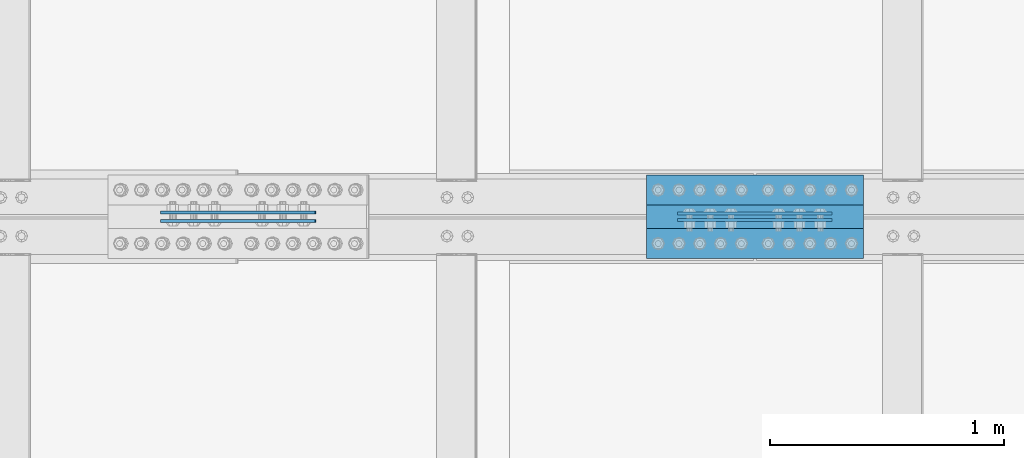
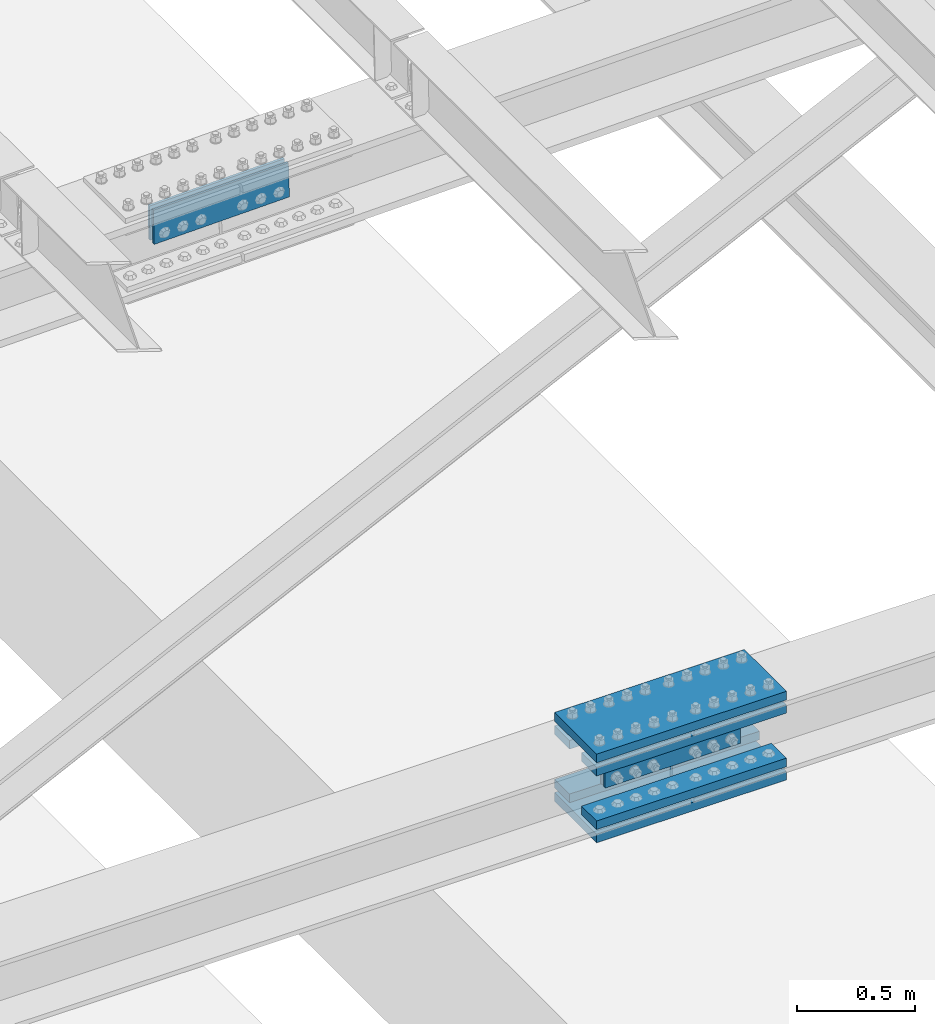
# One storey, part 2355 of 3843: 10 beams, 2 elements without a shape of their own.
"""IFC2X3 building model written with IfcOpenShell, lengths in millimetres."""

from ifc_helpers import new_model, si_unit, frame, origin_with_axes, place, context, subcontext, project, spatial, faceted_brep, material, type_object, element, aggregate, save


model = new_model("IFC2X3")

# Units and contexts
model_context = context("Model", 3, precision=1e-05, world=origin_with_axes())
body_context = subcontext(model_context, "Body", "Model", "MODEL_VIEW")
ifc_project = project(units=[si_unit("LENGTHUNIT", "METRE", prefix="MILLI"), si_unit("AREAUNIT", "SQUARE_METRE"), si_unit("VOLUMEUNIT", "CUBIC_METRE"), si_unit("MASSUNIT", "GRAM", prefix="KILO"), si_unit("TIMEUNIT", "SECOND"), si_unit("PLANEANGLEUNIT", "RADIAN"), si_unit("SOLIDANGLEUNIT", "STERADIAN"), si_unit("THERMODYNAMICTEMPERATUREUNIT", "DEGREE_CELSIUS"), si_unit("LUMINOUSINTENSITYUNIT", "LUMEN")], contexts=[model_context])

# Site, building, storey
site_placement = place(None, origin_with_axes())
site = spatial("IfcSite", under=ifc_project, at=site_placement, CompositionType="ELEMENT")
building_placement = place(site_placement, origin_with_axes())
building = spatial("IfcBuilding", under=site, at=building_placement, Name="Undefined", CompositionType="ELEMENT")
storey_placement = place(building_placement, origin_with_axes())
storey = spatial("IfcBuildingStorey", under=building, at=storey_placement, Name="Undefined", CompositionType="ELEMENT", Elevation=0.0)

# Assembly, beams
assembly_1_placement = place(storey_placement, origin_with_axes())
assembly_1 = element("IfcElementAssembly", 1, at=assembly_1_placement, inside=storey, Name="BEAM", AssemblyPlace="NOTDEFINED", PredefinedType="RIGID_FRAME")
ifc_material = material(Name="STEEL/A572-50")
beam_type_1 = type_object("IfcBeamType", PredefinedType="NOTDEFINED")
beam_1_placement = place(assembly_1_placement, frame((68046.60000049, 58901.80625, 42348.2024746643), z_axis=(-0.000295010000132606, 0.0, 0.999999956484549), x_axis=(-0.999999956484549, 0.0, -0.000295010000137217)))
beam_1 = element("IfcBeam", 2, at=beam_1_placement, type_object=beam_type_1, material=ifc_material, Name="PLATE", context=body_context, shape_type="Brep", body=[
    faceted_brep([(1.45519152283669e-11, 6.35000000000582, -88.8999999998996), (0.0, 6.34999999999854, 88.9000015258789), (660.399999982677, 6.35000000000582, 88.8999999999651), (660.399999982707, 6.35000000000582, -88.8999999998268), (0.0, -6.34999999999854, 88.9000015258789), (660.399999982677, -6.35000000000582, 88.8999999999651), (1.45519152283669e-11, -6.35000000000582, -88.8999999998996), (660.399999982707, -6.35000000000582, -88.8999999998268)], [[[0, 1, 2, 3]], [[1, 4, 5, 2]], [[4, 6, 7, 5]], [[6, 0, 3, 7]], [[5, 7, 3, 2]], [[6, 4, 1, 0]]]),
])
beam_2_placement = place(assembly_1_placement, frame((68046.60000049, 58928.79375, 42348.2024746643), z_axis=(-0.000295010000132606, 0.0, 0.999999956484549), x_axis=(-0.999999956484549, 0.0, -0.000295010000137217)))
beam_2 = element("IfcBeam", 3, at=beam_2_placement, type_object=beam_type_1, material=ifc_material, Name="PLATE", context=body_context, shape_type="Brep", body=[
    faceted_brep([(1.45519152283669e-11, 6.35000000000582, -88.8999999998996), (0.0, 6.34999999999854, 88.9000015258789), (660.399999982677, 6.35000000000582, 88.8999999999651), (660.399999982707, 6.35000000000582, -88.8999999998268), (0.0, -6.34999999999854, 88.9000015258789), (660.399999982677, -6.35000000000582, 88.8999999999651), (1.45519152283669e-11, -6.35000000000582, -88.8999999998996), (660.399999982707, -6.35000000000582, -88.8999999998268)], [[[0, 1, 2, 3]], [[1, 4, 5, 2]], [[4, 6, 7, 5]], [[6, 0, 3, 7]], [[5, 7, 3, 2]], [[6, 4, 1, 0]]]),
])

assembly_2_placement = place(storey_placement, origin_with_axes())
assembly_2 = element("IfcElementAssembly", 4, at=assembly_2_placement, inside=storey, Name="BEAM", AssemblyPlace="NOTDEFINED", PredefinedType="RIGID_FRAME")
beam_3_placement = place(assembly_2_placement, frame((65841.0254864261, 58932.7625, 45941.3441136831), z_axis=(0.0218666269940295, 0.0, -0.999760896726764), x_axis=(-0.999760896726764, 0.0, -0.0218666269940254)))
beam_3 = element("IfcBeam", 5, at=beam_3_placement, type_object=beam_type_1, material=ifc_material, Name="PLATE", context=body_context, shape_type="Brep", body=[
    faceted_brep([(1.45519152283669e-11, 6.35000000000582, -88.8999999998996), (0.0, 6.34999999999854, 88.9000015258789), (660.399999982677, 6.35000000000582, 88.8999999999651), (660.399999982707, 6.35000000000582, -88.8999999998268), (0.0, -6.34999999999854, 88.9000015258789), (660.399999982677, -6.35000000000582, 88.8999999999651), (1.45519152283669e-11, -6.35000000000582, -88.8999999998996), (660.399999982707, -6.35000000000582, -88.8999999998268)], [[[0, 1, 2, 3]], [[1, 4, 5, 2]], [[4, 6, 7, 5]], [[6, 0, 3, 7]], [[5, 7, 3, 2]], [[6, 4, 1, 0]]]),
])
beam_4_placement = place(assembly_2_placement, frame((65841.0254864261, 58897.8375, 45941.3441136831), z_axis=(0.0218666269940295, 0.0, -0.999760896726764), x_axis=(-0.999760896726764, 0.0, -0.0218666269940254)))
beam_4 = element("IfcBeam", 6, at=beam_4_placement, type_object=beam_type_1, material=ifc_material, Name="PLATE", context=body_context, shape_type="Brep", body=[
    faceted_brep([(1.45519152283669e-11, 6.35000000000582, -88.8999999998996), (0.0, 6.34999999999854, 88.9000015258789), (660.399999982677, 6.35000000000582, 88.8999999999651), (660.399999982707, 6.35000000000582, -88.8999999998268), (0.0, -6.34999999999854, 88.9000015258789), (660.399999982677, -6.35000000000582, 88.8999999999651), (1.45519152283669e-11, -6.35000000000582, -88.8999999998996), (660.399999982707, -6.35000000000582, -88.8999999998268)], [[[0, 1, 2, 3]], [[1, 4, 5, 2]], [[4, 6, 7, 5]], [[6, 0, 3, 7]], [[5, 7, 3, 2]], [[6, 4, 1, 0]]]),
])
aggregate(assembly_2, [beam_3, beam_4])

# Beam
beam_type_2 = type_object("IfcBeamType", PredefinedType="NOTDEFINED")
beam_5_placement = place(assembly_1_placement, frame((68180.0160130485, 58915.3, 42141.7878821881), z_axis=(0.0, 1.0, 0.0), x_axis=(-0.999999956484549, 0.0, -0.000295010000137217)))
beam_5 = element("IfcBeam", 7, at=beam_5_placement, type_object=beam_type_2, material=ifc_material, Name="PLATE", context=body_context, shape_type="Brep", body=[
    faceted_brep([(0.0, 22.2249999999767, -177.800000000003), (0.0, 22.2249999999767, 177.800000000003), (927.099999958984, 22.2250000000859, 177.800000000003), (927.099999958984, 22.2250000000859, -177.800000000003), (0.0, -22.2249999999694, 177.800000000003), (927.099999958984, -22.2249999998749, 177.800000000003), (0.0, -22.2249999999694, -177.800000000003), (927.099999958984, -22.2249999998749, -177.800000000003)], [[[0, 1, 2, 3]], [[1, 4, 5, 2]], [[4, 6, 7, 5]], [[6, 0, 3, 7]], [[5, 7, 3, 2]], [[6, 4, 1, 0]]]),
])

beam_6_placement = place(assembly_1_placement, frame((68179.8891123288, 58915.3, 42554.6159952864), z_axis=(0.0, 1.0, 0.0), x_axis=(-0.999999956484549, 0.0, -0.000295010000137217)))
beam_6 = element("IfcBeam", 8, at=beam_6_placement, type_object=beam_type_2, material=ifc_material, Name="PLATE", context=body_context, shape_type="Brep", body=[
    faceted_brep([(0.0, 22.2249999999767, -177.800000000003), (0.0, 22.2249999999767, 177.800000000003), (927.099999958984, 22.2250000000859, 177.800000000003), (927.099999958984, 22.2250000000859, -177.800000000003), (0.0, -22.2249999999694, 177.800000000003), (927.099999958984, -22.2249999998749, 177.800000000003), (0.0, -22.2249999999694, -177.800000000003), (927.099999958984, -22.2249999998749, -177.800000000003)], [[[0, 1, 2, 3]], [[1, 4, 5, 2]], [[4, 6, 7, 5]], [[6, 0, 3, 7]], [[5, 7, 3, 2]], [[6, 4, 1, 0]]]),
])

beam_type_3 = type_object("IfcBeamType", PredefinedType="NOTDEFINED")
beam_7_placement = place(assembly_1_placement, frame((67252.890799269, 58801.0, 42209.788848573), z_axis=(0.0, 1.0, 0.0), x_axis=(0.999999956484549, 0.0, 0.000295010000148233)))
beam_7 = element("IfcBeam", 9, at=beam_7_placement, type_object=beam_type_3, material=ifc_material, Name="PLATE", context=body_context, shape_type="Brep", body=[
    faceted_brep([(-7.27595761418343e-11, 22.2250000000786, -63.5), (-7.27595761418343e-11, 22.2250000000786, 63.5), (927.099999951592, 22.2250000031054, 63.5), (927.099999951592, 22.2250000031054, -63.5), (6.54836185276508e-11, -22.2250000000713, 63.5), (927.099999951744, -22.2249999970372, 63.5), (6.54836185276508e-11, -22.2250000000713, -63.5), (927.099999951744, -22.2249999970372, -63.5)], [[[0, 1, 2, 3]], [[1, 4, 5, 2]], [[4, 6, 7, 5]], [[6, 0, 3, 7]], [[5, 7, 3, 2]], [[6, 4, 1, 0]]]),
])

beam_8_placement = place(assembly_1_placement, frame((67252.8093137799, 58801.0, 42486.001863168), z_axis=(0.0, 1.0, 0.0), x_axis=(0.999999956484549, 0.0, 0.000295010000148233)))
beam_8 = element("IfcBeam", 10, at=beam_8_placement, type_object=beam_type_3, material=ifc_material, Name="PLATE", context=body_context, shape_type="Brep", body=[
    faceted_brep([(-7.27595761418343e-11, 22.2250000000786, -63.5), (-7.27595761418343e-11, 22.2250000000786, 63.5), (927.099999951592, 22.2250000031054, 63.5), (927.099999951592, 22.2250000031054, -63.5), (6.54836185276508e-11, -22.2250000000713, 63.5), (927.099999951744, -22.2249999970372, 63.5), (6.54836185276508e-11, -22.2250000000713, -63.5), (927.099999951744, -22.2249999970372, -63.5)], [[[0, 1, 2, 3]], [[1, 4, 5, 2]], [[4, 6, 7, 5]], [[6, 0, 3, 7]], [[5, 7, 3, 2]], [[6, 4, 1, 0]]]),
])

beam_9_placement = place(assembly_1_placement, frame((67252.890799269, 59029.6, 42209.788848573), z_axis=(0.0, 1.0, 0.0), x_axis=(0.999999956484549, 0.0, 0.000295010000148233)))
beam_9 = element("IfcBeam", 11, at=beam_9_placement, type_object=beam_type_3, material=ifc_material, Name="PLATE", context=body_context, shape_type="Brep", body=[
    faceted_brep([(-7.27595761418343e-11, 22.2250000000786, -63.5), (-7.27595761418343e-11, 22.2250000000786, 63.5), (927.099999951592, 22.2250000031054, 63.5), (927.099999951592, 22.2250000031054, -63.5), (6.54836185276508e-11, -22.2250000000713, 63.5), (927.099999951744, -22.2249999970372, 63.5), (6.54836185276508e-11, -22.2250000000713, -63.5), (927.099999951744, -22.2249999970372, -63.5)], [[[0, 1, 2, 3]], [[1, 4, 5, 2]], [[4, 6, 7, 5]], [[6, 0, 3, 7]], [[5, 7, 3, 2]], [[6, 4, 1, 0]]]),
])

beam_10_placement = place(assembly_1_placement, frame((67252.8093137799, 59029.6, 42486.001863168), z_axis=(0.0, 1.0, 0.0), x_axis=(0.999999956484549, 0.0, 0.000295010000148233)))
beam_10 = element("IfcBeam", 12, at=beam_10_placement, type_object=beam_type_3, material=ifc_material, Name="PLATE", context=body_context, shape_type="Brep", body=[
    faceted_brep([(-7.27595761418343e-11, 22.2250000000786, -63.5), (-7.27595761418343e-11, 22.2250000000786, 63.5), (927.099999951592, 22.2250000031054, 63.5), (927.099999951592, 22.2250000031054, -63.5), (6.54836185276508e-11, -22.2250000000713, 63.5), (927.099999951744, -22.2249999970372, 63.5), (6.54836185276508e-11, -22.2250000000713, -63.5), (927.099999951744, -22.2249999970372, -63.5)], [[[0, 1, 2, 3]], [[1, 4, 5, 2]], [[4, 6, 7, 5]], [[6, 0, 3, 7]], [[5, 7, 3, 2]], [[6, 4, 1, 0]]]),
])

aggregate(assembly_1, [beam_1, beam_2, beam_7, beam_8, beam_9, beam_10, beam_5, beam_6])

save(model, "model.ifc")
